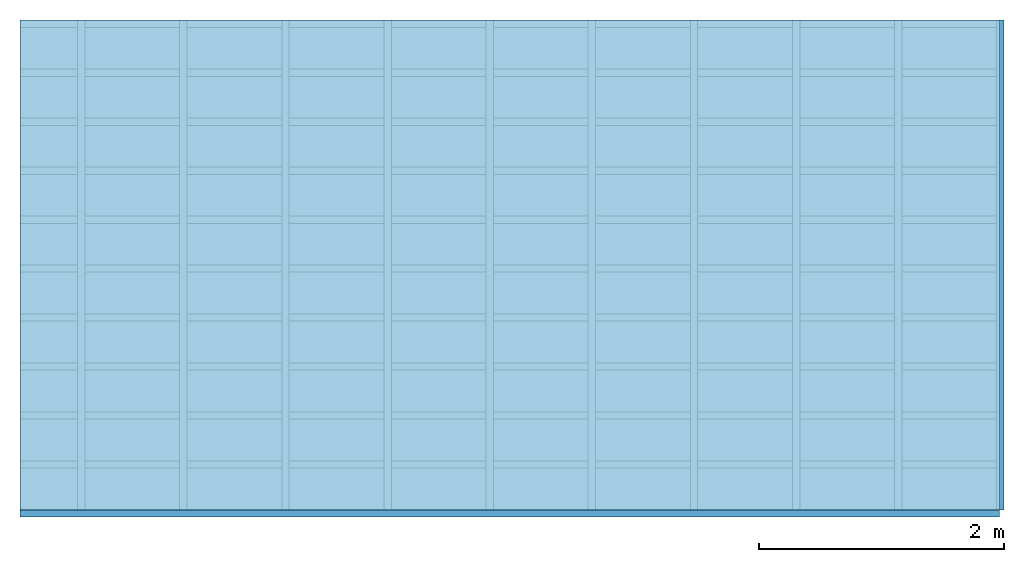
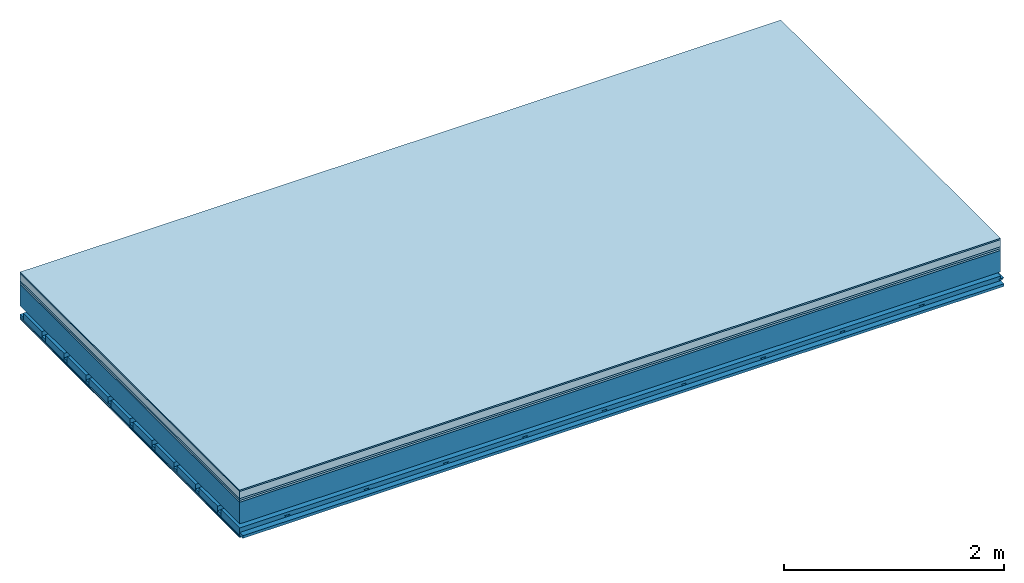
# One storey: 7 plates, 4 members, 1 element without a shape of its own.
"""IFC4 building model written with IfcOpenShell, lengths in metres."""

import ifcopenshell
import ifcopenshell.guid

model = None  # the IFC model being written
_history = None  # IfcOwnerHistory: only IFC2X3 demands one
_inside = {}  # id of a spatial element -> (the spatial element, [elements in it])
_under = {}  # id of a project, library or spatial element -> (it, [spatial elements below it])
_declared = {}  # id of a project -> (the project, [libraries it declares])
_typed = {}  # id of a type object -> (the type object, [elements of that type])
_made_of = {}  # id of a material, layer set ... -> (it, [elements and type objects made of it])


def new_model(schema):
    """Start an empty IFC model of exactly this schema.

    Asked for "IFC4X3", IfcOpenShell would pick the latest addendum, in which some entities
    have other attributes; the version numbers below select the first issue.
    IFC2X3 requires an IfcOwnerHistory on every rooted entity: one is made here for all.
    """
    global model, _history
    if schema == "IFC4X3":
        model = ifcopenshell.file(schema_version=(4, 3, 0, 0))
    else:
        model = ifcopenshell.file(schema=schema)
    _inside.clear()
    _under.clear()
    _declared.clear()
    _typed.clear()
    _made_of.clear()
    _history = None
    if model.schema == "IFC2X3":
        org = make("IfcOrganization", Name="unknown")
        user = make(
            "IfcPersonAndOrganization",
            ThePerson=make("IfcPerson", FamilyName="unknown"),
            TheOrganization=org,
        )
        app = make(
            "IfcApplication",
            ApplicationDeveloper=org,
            Version="unknown",
            ApplicationFullName="unknown",
            ApplicationIdentifier="unknown",
        )
        _history = make(
            "IfcOwnerHistory",
            OwningUser=user,
            OwningApplication=app,
            ChangeAction="ADDED",
            CreationDate=0,
        )
    return model


def make(cls, **values):
    """One entity of the class cls with the attributes given. An attribute that is None is left unset."""
    return model.create_entity(
        cls, **{name: value for name, value in values.items() if value is not None}
    )


def rooted(cls, **values):
    """An entity with a GlobalId (a new one), such as an element, a storey or a relation."""
    return make(cls, GlobalId=ifcopenshell.guid.new(), OwnerHistory=_history, **values)


def si_unit(unit_type, name, prefix=None):
    """IfcSIUnit, for example si_unit("LENGTHUNIT", "METRE", prefix="MILLI")."""
    return make("IfcSIUnit", UnitType=unit_type, Prefix=prefix, Name=name)


def derived_unit(unit_type, elements):
    """IfcDerivedUnit: a product of units, each with its exponent."""
    return make(
        "IfcDerivedUnit",
        Elements=[
            make("IfcDerivedUnitElement", Unit=unit, Exponent=power)
            for unit, power in elements
        ],
        UnitType=unit_type,
    )


def assignment(units):
    """IfcUnitAssignment: the units of a project."""
    return None if units is None else make("IfcUnitAssignment", Units=units)


def point(xyz):
    """IfcCartesianPoint."""
    return None if xyz is None else make("IfcCartesianPoint", Coordinates=xyz)


def direction(xyz):
    """IfcDirection."""
    return None if xyz is None else make("IfcDirection", DirectionRatios=xyz)


def frame(location, z_axis=None, x_axis=None):
    """IfcAxis2Placement3D, a coordinate frame: its origin and axes. An axis left out is left unset."""
    return make(
        "IfcAxis2Placement3D",
        Location=point(location),
        Axis=direction(z_axis),
        RefDirection=direction(x_axis),
    )


def frame_2d(location, x_axis=None):
    """IfcAxis2Placement2D, a coordinate frame in the plane: its origin and x axis."""
    return make(
        "IfcAxis2Placement2D", Location=point(location), RefDirection=direction(x_axis)
    )


def origin():
    """The frame at (0, 0, 0) with its axes left unset."""
    return frame((0.0, 0.0, 0.0))


def origin_with_axes():
    """The frame at (0, 0, 0) with the z axis (0, 0, 1) and the x axis (1, 0, 0) written out."""
    return frame((0.0, 0.0, 0.0), z_axis=(0.0, 0.0, 1.0), x_axis=(1.0, 0.0, 0.0))


def place(relative_to, where):
    """IfcLocalPlacement: puts the frame where relative to a parent placement (None: the world)."""
    return make(
        "IfcLocalPlacement", PlacementRelTo=relative_to, RelativePlacement=where
    )


def context(
    kind, dimensions, precision=None, world=None, true_north=None, identifier=None
):
    """IfcGeometricRepresentationContext, for example the 3D "Model" context."""
    return make(
        "IfcGeometricRepresentationContext",
        ContextIdentifier=identifier,
        ContextType=kind,
        CoordinateSpaceDimension=dimensions,
        Precision=precision,
        WorldCoordinateSystem=world,
        TrueNorth=true_north,
    )


def project(units=None, contexts=None):
    """IfcProject with its units and contexts."""
    return rooted(
        "IfcProject",
        Name="project",
        RepresentationContexts=contexts,
        UnitsInContext=assignment(units),
    )


def spatial(cls, under=None, at=None, **own):
    """A site, building, storey or space (cls), placed at a placement, below another one or the project."""
    s = rooted(cls, ObjectPlacement=at, **own)
    if under is not None:
        _under.setdefault(under.id(), (under, []))[1].append(s)
    return s


def polyline(points):
    """IfcPolyline through the points."""
    return make("IfcPolyline", Points=[point(p) for p in points])


def profile(cls, at=None, kind="AREA", **sizes):
    """A parametric profile (cls). Its sizes go by their IFC names, for example OverallWidth=200.0."""
    return make(cls, ProfileType=kind, Position=at, **sizes)


def rectangle(**sizes):
    """IfcRectangleProfileDef."""
    return profile("IfcRectangleProfileDef", **sizes)


def outline(outer, holes=None, kind="AREA"):
    """IfcArbitraryClosedProfileDef: a profile drawn as a closed curve; with holes, ...WithVoids."""
    if holes is None:
        return make("IfcArbitraryClosedProfileDef", ProfileType=kind, OuterCurve=outer)
    return make(
        "IfcArbitraryProfileDefWithVoids",
        ProfileType=kind,
        OuterCurve=outer,
        InnerCurves=holes,
    )


def extrude(swept, where, along, depth):
    """IfcExtrudedAreaSolid: the profile swept, set in the frame where, extruded along a direction by depth."""
    return make(
        "IfcExtrudedAreaSolid",
        SweptArea=swept,
        Position=where,
        ExtrudedDirection=direction(along),
        Depth=depth,
    )


def shape(context_of_items, identifier, shape_type, items):
    """IfcShapeRepresentation: the items that make up one representation, for example the "Body"."""
    return make(
        "IfcShapeRepresentation",
        ContextOfItems=context_of_items,
        RepresentationIdentifier=identifier,
        RepresentationType=shape_type,
        Items=items,
    )


def material(Name=None, Category=None):
    """IfcMaterial."""
    return make("IfcMaterial", Name=Name, Category=Category)


def layer(
    of_material, thickness, ventilated=None, Name=None, Category=None, Priority=None
):
    """IfcMaterialLayer: one layer of a wall or slab, of a material (None: an air gap)."""
    return make(
        "IfcMaterialLayer",
        Material=of_material,
        LayerThickness=thickness,
        IsVentilated=ventilated,
        Name=Name,
        Category=Category,
        Priority=Priority,
    )


def layer_set(layers, Name=None):
    """IfcMaterialLayerSet."""
    return make("IfcMaterialLayerSet", MaterialLayers=layers, LayerSetName=Name)


def made_of(thing, what):
    """Note that an element or type object is made of a material, layer set ...; save() writes the relation."""
    if what is not None:
        _made_of.setdefault(what.id(), (what, []))[1].append(thing)
    return thing


def type_object(cls, material=None, **own):
    """A type object (cls), such as IfcWallType, which elements share."""
    return made_of(rooted(cls, **own), material)


def element(
    cls,
    number,
    at=None,
    inside=None,
    cuts=None,
    type_object=None,
    material=None,
    context=None,
    identifier="Body",
    shape_type=None,
    held_by="IfcProductDefinitionShape",
    body=None,
    shapes=None,
    **own,
):
    """One element of the class cls, such as IfcWall. Its Tag is "e" and its number.

    at: its placement. inside: the storey or other place that contains it. cuts: it is an
    opening in that element (IfcRelVoidsElement). A single representation is given by context,
    identifier, shape_type and body (its items); several are given by shapes. held_by: the class
    of the entity that holds the representations. save() writes the other relations.
    """
    e = rooted(cls, Tag="e%d" % number, ObjectPlacement=at, **own)
    if body is not None:
        shapes = [shape(context, identifier, shape_type, body)]
    if shapes is not None:
        e.Representation = make(held_by, Representations=shapes)
    if inside is not None:
        _inside.setdefault(inside.id(), (inside, []))[1].append(e)
    if cuts is not None:
        rooted(
            "IfcRelVoidsElement", RelatingBuildingElement=cuts, RelatedOpeningElement=e
        )
    if type_object is not None:
        _typed.setdefault(type_object.id(), (type_object, []))[1].append(e)
    return made_of(e, material)


def aggregate(whole, parts):
    """IfcRelAggregates: a whole, such as a stair, and the parts it consists of."""
    return rooted("IfcRelAggregates", RelatingObject=whole, RelatedObjects=parts)


def save(model, path):
    """Write the relations noted so far, then the file.

    IfcRelAggregates (storeys below a building ...), IfcRelContainedInSpatialStructure (elements
    in a storey), IfcRelDefinesByType, IfcRelAssociatesMaterial and IfcRelDeclares: one each for
    every whole, place, type object, material and project.
    """
    for whole, parts in _under.values():
        aggregate(whole, parts)
    for where, things in _inside.values():
        rooted(
            "IfcRelContainedInSpatialStructure",
            RelatedElements=things,
            RelatingStructure=where,
        )
    for kind, things in _typed.values():
        rooted("IfcRelDefinesByType", RelatedObjects=things, RelatingType=kind)
    for what, things in _made_of.values():
        rooted("IfcRelAssociatesMaterial", RelatedObjects=things, RelatingMaterial=what)
    for by, libraries in _declared.values():
        rooted("IfcRelDeclares", RelatingContext=by, RelatedDefinitions=libraries)
    model.write(path)


model = new_model("IFC4")

# Units and contexts
plan_context = context("Plan", 3, precision=1e-05, world=origin(), true_north=direction((0.0, 1.0)))
model_context = context("Model", 3, precision=1e-05, world=origin(), true_north=direction((0.0, 1.0)))
ifc_project = project(units=[si_unit("LENGTHUNIT", "METRE"), derived_unit("SOUNDPRESSUREUNIT", [(si_unit("PRESSUREUNIT", "PASCAL", prefix="MICRO"), 0)]), si_unit("ENERGYUNIT", "JOULE", prefix="MEGA"), si_unit("MASSUNIT", "GRAM", prefix="KILO"), derived_unit("THERMALTRANSMITTANCEUNIT", [(si_unit("POWERUNIT", "WATT"), 1), (si_unit("AREAUNIT", "SQUARE_METRE"), -1), (si_unit("THERMODYNAMICTEMPERATUREUNIT", "KELVIN"), -1)]), derived_unit("AREADENSITYUNIT", [(si_unit("MASSUNIT", "GRAM", prefix="KILO"), 1), (si_unit("AREAUNIT", "SQUARE_METRE"), -1)]), derived_unit("USERDEFINED", [(si_unit("ENERGYUNIT", "JOULE", prefix="MEGA"), 1), (si_unit("AREAUNIT", "SQUARE_METRE"), -1)])], contexts=[plan_context, model_context])

# Site, building, storey
site = spatial("IfcSite", under=ifc_project)
building_placement = place(None, origin())
building = spatial("IfcBuilding", under=site, at=building_placement)
storey_placement = place(building_placement, origin())
storey = spatial("IfcBuildingStorey", under=building, at=storey_placement)

# Slab, members, plates
ifc_material_1 = material(Category="11.013")
ifc_layer_1 = layer(ifc_material_1, 0.015, Name="Flooring")
ifc_material_2 = material(Name="Cement screed", Category="04.006")
ifc_layer_2 = layer(ifc_material_2, 0.08, Name="On-material")
ifc_material_3 = material(Name="Wood fiber generic product", Category="10.009")
ifc_layer_3 = layer(ifc_material_3, 0.02, Name="Impact sound insulation")
ifc_material_4 = material(Category="10.004")
ifc_layer_4 = layer(ifc_material_4, 0.02, Name="Additional insulation")
ifc_material_5 = material(Name="no composite action")
ifc_layer_5 = layer(ifc_material_5, 0.0, Name="Bond")
ifc_layer_6 = layer(None, 0.24, Name="Supporting structure")
ifc_layer_7 = layer(ifc_material_5, 0.0, Name="Bond")
ifc_layer_8 = layer(None, 0.095, Name="Coupling")
ifc_layer_9 = layer(None, 0.03, Name="Battens / profiles")
ifc_material_6 = material(Name="Plasterboard type A", Category="03.008")
ifc_layer_10 = layer(ifc_material_6, 0.0125, Name="Ceiling covering 1st layer")
ifc_layer_11 = layer(ifc_material_6, 0.0125, Name="Ceiling covering layer 2")
ifc_material_7 = material(Category="04.001")
ifc_layer_12 = layer(ifc_material_7, 0.003, Name="Surface / treatment")
ifc_layer_set = layer_set([ifc_layer_1, ifc_layer_2, ifc_layer_3, ifc_layer_4, ifc_layer_5, ifc_layer_6, ifc_layer_7, ifc_layer_8, ifc_layer_9, ifc_layer_10, ifc_layer_11, ifc_layer_12])
slab_type = type_object("IfcSlabType", Name="A2156", PredefinedType="NOTDEFINED", material=ifc_layer_set)
slab_placement = place(None, frame((0.0, 0.0, 0.0), z_axis=(0.0, 0.0, -1.0), x_axis=(1.0, 0.0, 0.0)))
slab = element("IfcSlab", 1, at=slab_placement, inside=storey, type_object=slab_type, material=ifc_layer_set, Name="Slab #1")
ifc_material_8 = material(Name="Solid timber panel")
member_1_placement = place(slab_placement, origin())
member_1 = element("IfcMember", 2, at=member_1_placement, material=ifc_material_8, Name="Supporting structure", context=plan_context, shape_type="SweptSolid", body=[
    extrude(rectangle(XDim=1.0, YDim=0.24, at=frame_2d((0.5, 0.12), x_axis=(1.0, 0.0))), frame((0.0, 4.0, 0.135), z_axis=(0.0, -1.0, 0.0), x_axis=(1.0, 0.0, 0.0)), (0.0, 0.0, 1.0), 4.0),
    extrude(rectangle(XDim=1.0, YDim=0.24, at=frame_2d((0.5, 0.12), x_axis=(1.0, 0.0))), frame((1.0, 4.0, 0.135), z_axis=(0.0, -1.0, 0.0), x_axis=(1.0, 0.0, 0.0)), (0.0, 0.0, 1.0), 4.0),
    extrude(rectangle(XDim=1.0, YDim=0.24, at=frame_2d((0.5, 0.12), x_axis=(1.0, 0.0))), frame((2.0, 4.0, 0.135), z_axis=(0.0, -1.0, 0.0), x_axis=(1.0, 0.0, 0.0)), (0.0, 0.0, 1.0), 4.0),
    extrude(rectangle(XDim=1.0, YDim=0.24, at=frame_2d((0.5, 0.12), x_axis=(1.0, 0.0))), frame((3.0, 4.0, 0.135), z_axis=(0.0, -1.0, 0.0), x_axis=(1.0, 0.0, 0.0)), (0.0, 0.0, 1.0), 4.0),
    extrude(rectangle(XDim=1.0, YDim=0.24, at=frame_2d((0.5, 0.12), x_axis=(1.0, 0.0))), frame((4.0, 4.0, 0.135), z_axis=(0.0, -1.0, 0.0), x_axis=(1.0, 0.0, 0.0)), (0.0, 0.0, 1.0), 4.0),
    extrude(rectangle(XDim=1.0, YDim=0.24, at=frame_2d((0.5, 0.12), x_axis=(1.0, 0.0))), frame((5.0, 4.0, 0.135), z_axis=(0.0, -1.0, 0.0), x_axis=(1.0, 0.0, 0.0)), (0.0, 0.0, 1.0), 4.0),
    extrude(rectangle(XDim=1.0, YDim=0.24, at=frame_2d((0.5, 0.12), x_axis=(1.0, 0.0))), frame((6.0, 4.0, 0.135), z_axis=(0.0, -1.0, 0.0), x_axis=(1.0, 0.0, 0.0)), (0.0, 0.0, 1.0), 4.0),
    extrude(rectangle(XDim=1.0, YDim=0.24, at=frame_2d((0.5, 0.12), x_axis=(1.0, 0.0))), frame((7.0, 4.0, 0.135), z_axis=(0.0, -1.0, 0.0), x_axis=(1.0, 0.0, 0.0)), (0.0, 0.0, 1.0), 4.0),
])
ifc_material_9 = material()
member_2_placement = place(slab_placement, origin())
member_2 = element("IfcMember", 3, at=member_2_placement, material=ifc_material_9, Name="Coupling", context=plan_context, shape_type="SweptSolid", body=[
    extrude(outline(polyline([(0.0, 0.0), (0.06, 0.0), (0.04, 0.02), (0.02, 0.02), (0.0, 0.0)])), frame((0.47, 4.0, 0.45), z_axis=(0.0, -1.0, 0.0), x_axis=(1.0, 0.0, 0.0)), (0.0, 0.0, 1.0), 4.0),
    extrude(outline(polyline([(0.0, 0.0), (0.06, 0.0), (0.04, 0.02), (0.02, 0.02), (0.0, 0.0)])), frame((1.304, 4.0, 0.45), z_axis=(0.0, -1.0, 0.0), x_axis=(1.0, 0.0, 0.0)), (0.0, 0.0, 1.0), 4.0),
    extrude(outline(polyline([(0.0, 0.0), (0.06, 0.0), (0.04, 0.02), (0.02, 0.02), (0.0, 0.0)])), frame((2.138, 4.0, 0.45), z_axis=(0.0, -1.0, 0.0), x_axis=(1.0, 0.0, 0.0)), (0.0, 0.0, 1.0), 4.0),
    extrude(outline(polyline([(0.0, 0.0), (0.06, 0.0), (0.04, 0.02), (0.02, 0.02), (0.0, 0.0)])), frame((2.972, 4.0, 0.45), z_axis=(0.0, -1.0, 0.0), x_axis=(1.0, 0.0, 0.0)), (0.0, 0.0, 1.0), 4.0),
    extrude(outline(polyline([(0.0, 0.0), (0.06, 0.0), (0.04, 0.02), (0.02, 0.02), (0.0, 0.0)])), frame((3.806, 4.0, 0.45), z_axis=(0.0, -1.0, 0.0), x_axis=(1.0, 0.0, 0.0)), (0.0, 0.0, 1.0), 4.0),
    extrude(outline(polyline([(0.0, 0.0), (0.06, 0.0), (0.04, 0.02), (0.02, 0.02), (0.0, 0.0)])), frame((4.64, 4.0, 0.45), z_axis=(0.0, -1.0, 0.0), x_axis=(1.0, 0.0, 0.0)), (0.0, 0.0, 1.0), 4.0),
    extrude(outline(polyline([(0.0, 0.0), (0.06, 0.0), (0.04, 0.02), (0.02, 0.02), (0.0, 0.0)])), frame((5.474, 4.0, 0.45), z_axis=(0.0, -1.0, 0.0), x_axis=(1.0, 0.0, 0.0)), (0.0, 0.0, 1.0), 4.0),
    extrude(outline(polyline([(0.0, 0.0), (0.06, 0.0), (0.04, 0.02), (0.02, 0.02), (0.0, 0.0)])), frame((6.308, 4.0, 0.45), z_axis=(0.0, -1.0, 0.0), x_axis=(1.0, 0.0, 0.0)), (0.0, 0.0, 1.0), 4.0),
    extrude(outline(polyline([(0.0, 0.0), (0.06, 0.0), (0.04, 0.02), (0.02, 0.02), (0.0, 0.0)])), frame((7.142, 4.0, 0.45), z_axis=(0.0, -1.0, 0.0), x_axis=(1.0, 0.0, 0.0)), (0.0, 0.0, 1.0), 4.0),
    extrude(outline(polyline([(0.0, 0.0), (0.06, 0.0), (0.04, 0.02), (0.02, 0.02), (0.0, 0.0)])), frame((7.976, 4.0, 0.45), z_axis=(0.0, -1.0, 0.0), x_axis=(1.0, 0.0, 0.0)), (0.0, 0.0, 1.0), 4.0),
])
member_3_placement = place(slab_placement, origin())
member_3 = element("IfcMember", 4, at=member_3_placement, material=ifc_material_9, Name="Battens / profiles", context=plan_context, shape_type="SweptSolid", body=[
    extrude(rectangle(XDim=0.06, YDim=0.03, at=frame_2d((0.03, 0.015), x_axis=(1.0, 0.0))), frame((0.0, 0.0, 0.47), z_axis=(1.0, 0.0, 0.0), x_axis=(0.0, 1.0, 0.0)), (0.0, 0.0, 1.0), 8.0),
    extrude(rectangle(XDim=0.06, YDim=0.03, at=frame_2d((0.03, 0.015), x_axis=(1.0, 0.0))), frame((0.0, 0.4, 0.47), z_axis=(1.0, 0.0, 0.0), x_axis=(0.0, 1.0, 0.0)), (0.0, 0.0, 1.0), 8.0),
    extrude(rectangle(XDim=0.06, YDim=0.03, at=frame_2d((0.03, 0.015), x_axis=(1.0, 0.0))), frame((0.0, 0.8, 0.47), z_axis=(1.0, 0.0, 0.0), x_axis=(0.0, 1.0, 0.0)), (0.0, 0.0, 1.0), 8.0),
    extrude(rectangle(XDim=0.06, YDim=0.03, at=frame_2d((0.03, 0.015), x_axis=(1.0, 0.0))), frame((0.0, 1.2, 0.47), z_axis=(1.0, 0.0, 0.0), x_axis=(0.0, 1.0, 0.0)), (0.0, 0.0, 1.0), 8.0),
    extrude(rectangle(XDim=0.06, YDim=0.03, at=frame_2d((0.03, 0.015), x_axis=(1.0, 0.0))), frame((0.0, 1.6, 0.47), z_axis=(1.0, 0.0, 0.0), x_axis=(0.0, 1.0, 0.0)), (0.0, 0.0, 1.0), 8.0),
    extrude(rectangle(XDim=0.06, YDim=0.03, at=frame_2d((0.03, 0.015), x_axis=(1.0, 0.0))), frame((0.0, 2.0, 0.47), z_axis=(1.0, 0.0, 0.0), x_axis=(0.0, 1.0, 0.0)), (0.0, 0.0, 1.0), 8.0),
    extrude(rectangle(XDim=0.06, YDim=0.03, at=frame_2d((0.03, 0.015), x_axis=(1.0, 0.0))), frame((0.0, 2.4, 0.47), z_axis=(1.0, 0.0, 0.0), x_axis=(0.0, 1.0, 0.0)), (0.0, 0.0, 1.0), 8.0),
    extrude(rectangle(XDim=0.06, YDim=0.03, at=frame_2d((0.03, 0.015), x_axis=(1.0, 0.0))), frame((0.0, 2.8, 0.47), z_axis=(1.0, 0.0, 0.0), x_axis=(0.0, 1.0, 0.0)), (0.0, 0.0, 1.0), 8.0),
    extrude(rectangle(XDim=0.06, YDim=0.03, at=frame_2d((0.03, 0.015), x_axis=(1.0, 0.0))), frame((0.0, 3.2, 0.47), z_axis=(1.0, 0.0, 0.0), x_axis=(0.0, 1.0, 0.0)), (0.0, 0.0, 1.0), 8.0),
    extrude(rectangle(XDim=0.06, YDim=0.03, at=frame_2d((0.03, 0.015), x_axis=(1.0, 0.0))), frame((0.0, 3.6, 0.47), z_axis=(1.0, 0.0, 0.0), x_axis=(0.0, 1.0, 0.0)), (0.0, 0.0, 1.0), 8.0),
    extrude(rectangle(XDim=0.06, YDim=0.03, at=frame_2d((0.03, 0.015), x_axis=(1.0, 0.0))), frame((0.0, 4.0, 0.47), z_axis=(1.0, 0.0, 0.0), x_axis=(0.0, 1.0, 0.0)), (0.0, 0.0, 1.0), 8.0),
])
ifc_material_10 = material()
member_4_placement = place(slab_placement, origin())
member_4 = element("IfcMember", 5, at=member_4_placement, material=ifc_material_10, Name="Cavity", context=plan_context, shape_type="SweptSolid", body=[
    extrude(rectangle(XDim=0.34, YDim=0.08, at=frame_2d((0.17, 0.04), x_axis=(1.0, 0.0))), frame((0.0, 0.06, 0.42), z_axis=(1.0, 0.0, 0.0), x_axis=(0.0, 1.0, 0.0)), (0.0, 0.0, 1.0), 8.0),
    extrude(rectangle(XDim=0.34, YDim=0.08, at=frame_2d((0.17, 0.04), x_axis=(1.0, 0.0))), frame((0.0, 0.46, 0.42), z_axis=(1.0, 0.0, 0.0), x_axis=(0.0, 1.0, 0.0)), (0.0, 0.0, 1.0), 8.0),
    extrude(rectangle(XDim=0.34, YDim=0.08, at=frame_2d((0.17, 0.04), x_axis=(1.0, 0.0))), frame((0.0, 0.86, 0.42), z_axis=(1.0, 0.0, 0.0), x_axis=(0.0, 1.0, 0.0)), (0.0, 0.0, 1.0), 8.0),
    extrude(rectangle(XDim=0.34, YDim=0.08, at=frame_2d((0.17, 0.04), x_axis=(1.0, 0.0))), frame((0.0, 1.26, 0.42), z_axis=(1.0, 0.0, 0.0), x_axis=(0.0, 1.0, 0.0)), (0.0, 0.0, 1.0), 8.0),
    extrude(rectangle(XDim=0.34, YDim=0.08, at=frame_2d((0.17, 0.04), x_axis=(1.0, 0.0))), frame((0.0, 1.66, 0.42), z_axis=(1.0, 0.0, 0.0), x_axis=(0.0, 1.0, 0.0)), (0.0, 0.0, 1.0), 8.0),
    extrude(rectangle(XDim=0.34, YDim=0.08, at=frame_2d((0.17, 0.04), x_axis=(1.0, 0.0))), frame((0.0, 2.06, 0.42), z_axis=(1.0, 0.0, 0.0), x_axis=(0.0, 1.0, 0.0)), (0.0, 0.0, 1.0), 8.0),
    extrude(rectangle(XDim=0.34, YDim=0.08, at=frame_2d((0.17, 0.04), x_axis=(1.0, 0.0))), frame((0.0, 2.46, 0.42), z_axis=(1.0, 0.0, 0.0), x_axis=(0.0, 1.0, 0.0)), (0.0, 0.0, 1.0), 8.0),
    extrude(rectangle(XDim=0.34, YDim=0.08, at=frame_2d((0.17, 0.04), x_axis=(1.0, 0.0))), frame((0.0, 2.86, 0.42), z_axis=(1.0, 0.0, 0.0), x_axis=(0.0, 1.0, 0.0)), (0.0, 0.0, 1.0), 8.0),
    extrude(rectangle(XDim=0.34, YDim=0.08, at=frame_2d((0.17, 0.04), x_axis=(1.0, 0.0))), frame((0.0, 3.26, 0.42), z_axis=(1.0, 0.0, 0.0), x_axis=(0.0, 1.0, 0.0)), (0.0, 0.0, 1.0), 8.0),
    extrude(rectangle(XDim=0.34, YDim=0.08, at=frame_2d((0.17, 0.04), x_axis=(1.0, 0.0))), frame((0.0, 3.66, 0.42), z_axis=(1.0, 0.0, 0.0), x_axis=(0.0, 1.0, 0.0)), (0.0, 0.0, 1.0), 8.0),
])
plate_1_placement = place(slab_placement, origin())
plate_1 = element("IfcPlate", 6, at=plate_1_placement, material=ifc_material_1, Name="Flooring", context=plan_context, shape_type="SweptSolid", body=[
    extrude(rectangle(XDim=8.0, YDim=4.0, at=frame_2d((4.0, 2.0), x_axis=(1.0, 0.0))), origin_with_axes(), (0.0, 0.0, 1.0), 0.015),
])
plate_2_placement = place(slab_placement, origin())
plate_2 = element("IfcPlate", 7, at=plate_2_placement, material=ifc_material_2, Name="On-material", context=plan_context, shape_type="SweptSolid", body=[
    extrude(rectangle(XDim=8.0, YDim=4.0, at=frame_2d((4.0, 2.0), x_axis=(1.0, 0.0))), frame((0.0, 0.0, 0.015), z_axis=(0.0, 0.0, 1.0), x_axis=(1.0, 0.0, 0.0)), (0.0, 0.0, 1.0), 0.08),
])
plate_3_placement = place(slab_placement, origin())
plate_3 = element("IfcPlate", 8, at=plate_3_placement, material=ifc_material_3, Name="Impact sound insulation", context=plan_context, shape_type="SweptSolid", body=[
    extrude(rectangle(XDim=8.0, YDim=4.0, at=frame_2d((4.0, 2.0), x_axis=(1.0, 0.0))), frame((0.0, 0.0, 0.095), z_axis=(0.0, 0.0, 1.0), x_axis=(1.0, 0.0, 0.0)), (0.0, 0.0, 1.0), 0.02),
])
plate_4_placement = place(slab_placement, origin())
plate_4 = element("IfcPlate", 9, at=plate_4_placement, material=ifc_material_4, Name="Additional insulation", context=plan_context, shape_type="SweptSolid", body=[
    extrude(rectangle(XDim=8.0, YDim=4.0, at=frame_2d((4.0, 2.0), x_axis=(1.0, 0.0))), frame((0.0, 0.0, 0.115), z_axis=(0.0, 0.0, 1.0), x_axis=(1.0, 0.0, 0.0)), (0.0, 0.0, 1.0), 0.02),
])
plate_5_placement = place(slab_placement, origin())
plate_5 = element("IfcPlate", 10, at=plate_5_placement, material=ifc_material_6, Name="Ceiling covering 1st layer", context=plan_context, shape_type="SweptSolid", body=[
    extrude(rectangle(XDim=8.0, YDim=4.0, at=frame_2d((4.0, 2.0), x_axis=(1.0, 0.0))), frame((0.0, 0.0, 0.5), z_axis=(0.0, 0.0, 1.0), x_axis=(1.0, 0.0, 0.0)), (0.0, 0.0, 1.0), 0.0125),
])
plate_6_placement = place(slab_placement, origin())
plate_6 = element("IfcPlate", 11, at=plate_6_placement, material=ifc_material_6, Name="Ceiling covering layer 2", context=plan_context, shape_type="SweptSolid", body=[
    extrude(rectangle(XDim=8.0, YDim=4.0, at=frame_2d((4.0, 2.0), x_axis=(1.0, 0.0))), frame((0.0, 0.0, 0.5125), z_axis=(0.0, 0.0, 1.0), x_axis=(1.0, 0.0, 0.0)), (0.0, 0.0, 1.0), 0.0125),
])
plate_7_placement = place(slab_placement, origin())
plate_7 = element("IfcPlate", 12, at=plate_7_placement, material=ifc_material_7, Name="Surface / treatment", context=plan_context, shape_type="SweptSolid", body=[
    extrude(rectangle(XDim=8.0, YDim=4.0, at=frame_2d((4.0, 2.0), x_axis=(1.0, 0.0))), frame((0.0, 0.0, 0.525), z_axis=(0.0, 0.0, 1.0), x_axis=(1.0, 0.0, 0.0)), (0.0, 0.0, 1.0), 0.003),
])
aggregate(slab, [plate_1, plate_2, plate_3, plate_4, member_1, member_2, member_3, member_4, plate_5, plate_6, plate_7])

save(model, "model.ifc")
